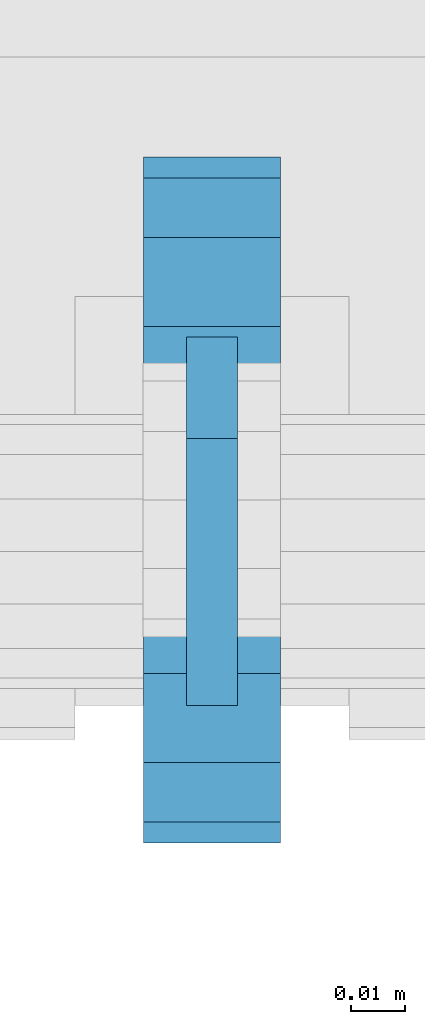
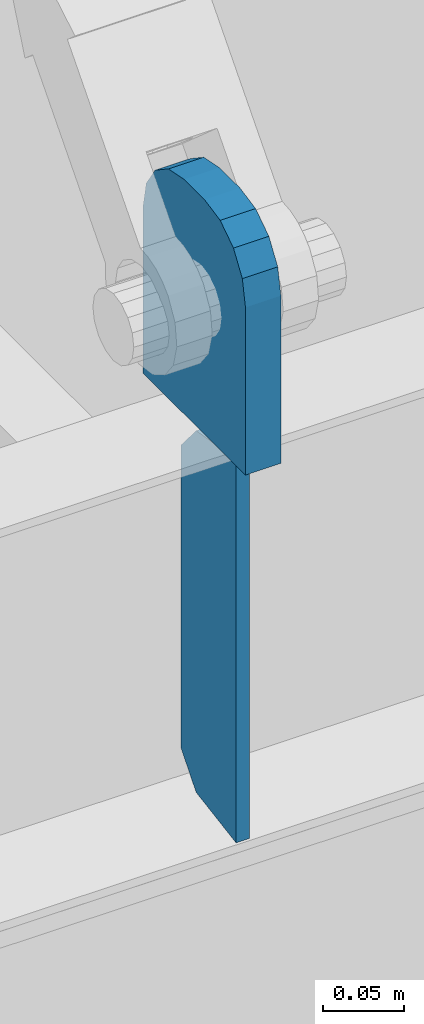
# One storey, part 1460 of 1763: 2 plates, 1 element without a shape of its own.
"""IFC2X3 building model written with IfcOpenShell, lengths in millimetres."""

from ifc_helpers import new_model, si_unit, frame, origin_with_axes, place, context, subcontext, project, spatial, faceted_brep, material, type_object, element, aggregate, save


model = new_model("IFC2X3")

# Units and contexts
model_context = context("Model", 3, precision=1e-05, world=origin_with_axes())
body_context = subcontext(model_context, "Body", "Model", "MODEL_VIEW")
ifc_project = project(units=[si_unit("LENGTHUNIT", "METRE", prefix="MILLI"), si_unit("AREAUNIT", "SQUARE_METRE"), si_unit("VOLUMEUNIT", "CUBIC_METRE"), si_unit("MASSUNIT", "GRAM", prefix="KILO"), si_unit("TIMEUNIT", "SECOND"), si_unit("PLANEANGLEUNIT", "RADIAN"), si_unit("SOLIDANGLEUNIT", "STERADIAN"), si_unit("THERMODYNAMICTEMPERATUREUNIT", "DEGREE_CELSIUS"), si_unit("LUMINOUSINTENSITYUNIT", "LUMEN")], contexts=[model_context])

# Site, building, storey
site_placement = place(None, origin_with_axes())
site = spatial("IfcSite", under=ifc_project, at=site_placement, CompositionType="ELEMENT")
building_placement = place(site_placement, origin_with_axes())
building = spatial("IfcBuilding", under=site, at=building_placement, Name="Undefined", CompositionType="ELEMENT")
storey_placement = place(building_placement, origin_with_axes())
storey = spatial("IfcBuildingStorey", under=building, at=storey_placement, Name="Undefined", CompositionType="ELEMENT", Elevation=0.0)

# Assembly, plates
assembly_placement = place(storey_placement, origin_with_axes())
assembly = element("IfcElementAssembly", 1, at=assembly_placement, inside=storey, Name="BEAM", AssemblyPlace="NOTDEFINED", PredefinedType="RIGID_FRAME")
ifc_material = material(Name="STEEL/A36")
plate_type_1 = type_object("IfcPlateType", PredefinedType="NOTDEFINED")
plate_1_placement = place(assembly_placement, frame((-52018.627008321, -16681.452583842, 8440.7619207156), z_axis=(0.0, -0.164335003932505, 0.986404585594828), x_axis=(0.0, 0.986404585594827, 0.164335003932507)))
plate_1 = element("IfcPlate", 2, at=plate_1_placement, type_object=plate_type_1, material=ifc_material, Name="PLATE", context=body_context, shape_type="Brep", body=[
    faceted_brep([(0.0, -4.76249999999982, 0.0), (47.7369384761423, -4.76249999999709, 286.536254883109), (47.7369384761423, 4.76249999999709, 286.536254883109), (0.0, 4.76249999999982, 0.0), (95.1814043146169, -4.76249999999709, 270.276469957982), (95.1814043146169, 4.76249999999709, 270.276469957982), (110.071894935774, -4.76249999999709, 245.309426724465), (110.071894935774, 4.76249999999709, 245.309426724465), (72.333927817599, -4.76249999999709, 18.7910066254462), (72.333927817599, 4.76249999999709, 18.7910066254462), (50.1533470153317, -4.76249999999709, 3.09228198602796e-11), (50.1533470153317, 4.76249999999709, 3.09228198602796e-11)], [[[0, 1, 2, 3]], [[1, 4, 5, 2]], [[4, 6, 7, 5]], [[6, 8, 9, 7]], [[8, 10, 11, 9]], [[10, 0, 3, 11]], [[5, 7, 9, 11, 3, 2]], [[10, 8, 6, 4, 1, 0]]]),
])
plate_type_2 = type_object("IfcPlateType", PredefinedType="NOTDEFINED")
plate_2_placement = place(assembly_placement, frame((-52018.627008321, -16706.8525869816, 8915.4), z_axis=(0.0, 1.0, 0.0), x_axis=(0.0, 0.0, -1.0)))
plate_2 = element("IfcPlate", 3, at=plate_2_placement, type_object=plate_type_2, material=ifc_material, Name="PLATE", context=body_context, shape_type="Brep", body=[
    faceted_brep([(0.0, -12.6999999999971, 50.7999992370605), (-5.45696821063757e-12, -12.7000000000098, 76.1999999999971), (5.45696821063757e-12, 12.7000000000116, 76.1999999999971), (0.0, 12.6999999999971, 50.7999992370605), (3.86691969035201, -12.6999999999971, 95.6403188351214), (3.86691969035201, 12.6999999999971, 95.6403188351214), (14.8789752922639, -12.6999999999971, 112.121024707736), (14.8789752922639, 12.6999999999971, 112.121024707736), (31.3596811648786, -12.6999999999971, 123.13308030965), (31.3596811648786, 12.6999999999971, 123.13308030965), (50.7999992370605, -12.6999999999971, 127.0), (50.7999992370605, 12.6999999999971, 127.0), (177.800003051758, -12.6999999999971, 127.0), (177.800003051758, 12.6999999999971, 127.0), (177.800003051758, -12.6999999999971, 0.0), (177.800003051758, 12.6999999999971, 0.0), (50.7999992370605, -12.6999999999971, 0.0), (50.7999992370605, 12.6999999999971, 0.0), (31.3596811648786, -12.6999999999971, 3.86691969035019), (31.3596811648786, 12.6999999999971, 3.86691969035019), (14.8789752922639, -12.6999999999971, 14.8789752922639), (14.8789752922639, 12.6999999999971, 14.8789752922639), (3.86691969035201, -12.6999999999971, 31.3596811648786), (3.86691969035201, 12.6999999999971, 31.3596811648786)], [[[0, 1, 2, 3]], [[1, 4, 5, 2]], [[4, 6, 7, 5]], [[6, 8, 9, 7]], [[8, 10, 11, 9]], [[10, 12, 13, 11]], [[12, 14, 15, 13]], [[14, 16, 17, 15]], [[16, 18, 19, 17]], [[18, 20, 21, 19]], [[20, 22, 23, 21]], [[22, 0, 3, 23]], [[5, 7, 9, 11, 13, 15, 17, 19, 21, 23, 3, 2]], [[22, 20, 18, 16, 14, 12, 10, 8, 6, 4, 1, 0]]]),
])
aggregate(assembly, [plate_1, plate_2])

save(model, "model.ifc")
